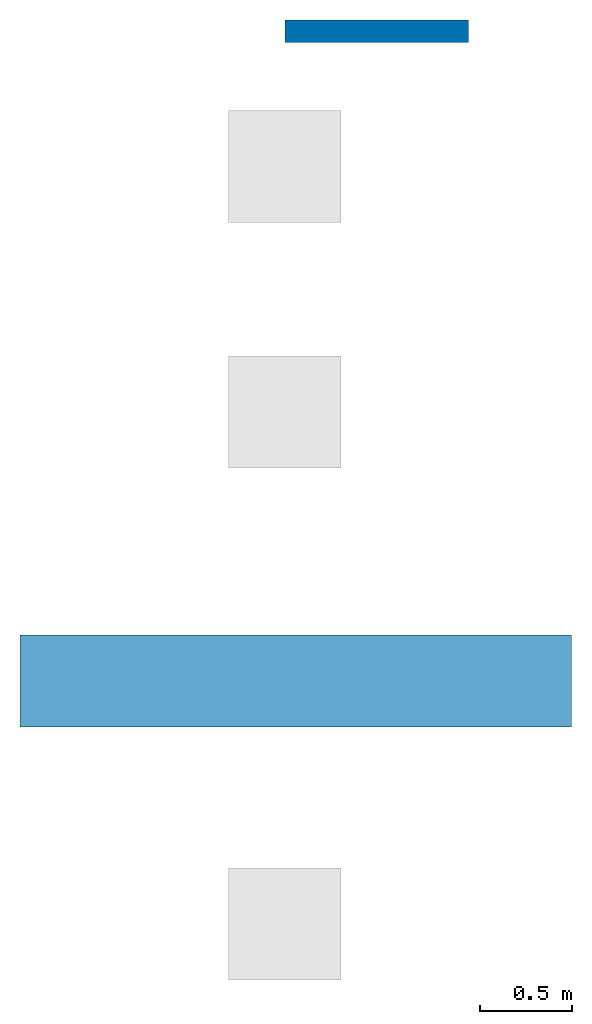
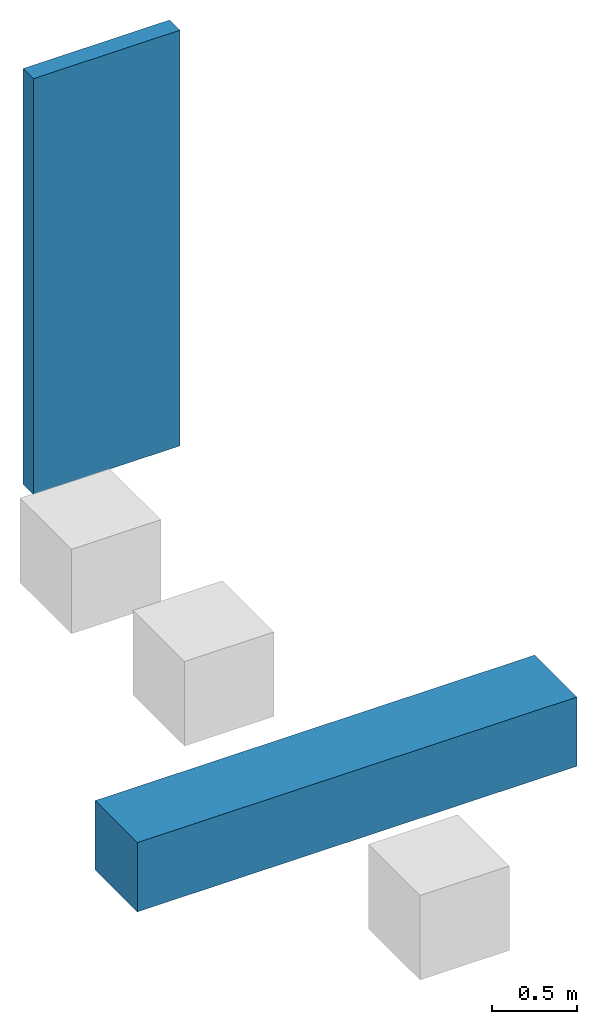
# One storey, part 1 of 2: 1 beam, 1 wall.
"""IFC4 building model written with IfcOpenShell, lengths in feet."""

from ifc_helpers import new_model, entity, si_unit, converted_unit, frame, origin_with_axes, origin_2d_with_axis, place, context, subcontext, project, spatial, indexed_curve, rectangle, outline, extrude, material, layer, layer_set, layer_usage, material_profile, profile_set, profile_usage, type_object, element, save


model = new_model("IFC4")

# Units and contexts
model_context = context("Model", 3, precision=1e-05, world=origin_with_axes())
plan_context = context("Plan", 2, precision=1e-05, world=origin_2d_with_axis())
body_context = subcontext(model_context, "Body", "Model", "MODEL_VIEW")
ifc_project = project(units=[converted_unit("AREAUNIT", "square foot", entity("IfcReal", 0.09290304), si_unit("AREAUNIT", "SQUARE_METRE"), dimensions=[2, 0, 0, 0, 0, 0, 0]), converted_unit("LENGTHUNIT", "foot", entity("IfcReal", 0.3048), si_unit("LENGTHUNIT", "METRE"), dimensions=[1, 0, 0, 0, 0, 0, 0]), converted_unit("VOLUMEUNIT", "cubic foot", entity("IfcReal", 0.0283168467116885), si_unit("VOLUMEUNIT", "CUBIC_METRE"), dimensions=[3, 0, 0, 0, 0, 0, 0]), converted_unit("PLANEANGLEUNIT", "degree", entity("IfcReal", 0.0174532925199433), si_unit("PLANEANGLEUNIT", "RADIAN"), dimensions=[0, 0, 0, 0, 0, 0, 0])], contexts=[model_context, plan_context])

# Site, building, storey
site_placement = place(None, origin_with_axes())
site = spatial("IfcSite", under=ifc_project, at=site_placement)
building_placement = place(site_placement, origin_with_axes())
building = spatial("IfcBuilding", under=site, at=building_placement, Name="Building")
storey_placement = place(building_placement, origin_with_axes())
storey = spatial("IfcBuildingStorey", under=building, at=storey_placement, Name="Storey")

# Beam
ifc_material_1 = material(Name="1_Material")
ifc_material_profile = material_profile(ifc_material_1, rectangle(XDim=1.64041994750656, YDim=1.64041994750656))
ifc_profile_set = profile_set([ifc_material_profile])
ifc_profile_usage = profile_usage(ifc_profile_set, cardinal=5)
beam_type = type_object("IfcBeamType", PredefinedType="BEAM", material=ifc_profile_set)
beam_placement = place(storey_placement, frame((-4.72472565067722, -11.3989627893203, 0.0), z_axis=(0.999999999999994, -7.54979012640429e-08, 7.54979012640429e-08), x_axis=(7.54979012640431e-08, 0.999999999999997, 7.16093850883224e-15)))
element("IfcBeam", 1, at=beam_placement, inside=storey, type_object=beam_type, material=ifc_profile_usage, Name="Beam", context=body_context, shape_type="SweptSolid", body=[
    extrude(rectangle(XDim=1.64041994750656, YDim=1.64041994750656), origin_with_axes(), (0.0, 0.0, 1.0), 9.84251968503943),
])

# Wall
ifc_layer_1 = layer(ifc_material_1, 0.200000002980232)
ifc_material_2 = material(Name="2_Material")
ifc_layer_2 = layer(ifc_material_2, 0.200000002980232)
ifc_layer_set = layer_set([ifc_layer_1, ifc_layer_2])
ifc_layer_usage = layer_usage(ifc_layer_set, "AXIS2", "POSITIVE", 0.0)
wall_type = type_object("IfcWallType", PredefinedType="SOLIDWALL", material=ifc_layer_set)
wall_placement = place(storey_placement, origin_with_axes())
element("IfcWall", 2, at=wall_placement, inside=storey, type_object=wall_type, material=ifc_layer_usage, Name="Wall", context=body_context, shape_type="SweptSolid", body=[
    extrude(outline(indexed_curve([(0.0, 0.0), (0.0, 0.400000005960464), (3.28083989501312, 0.400000005960464), (3.28083989501312, 0.0), (0.0, 0.0)], self_intersect=False)), origin_with_axes(), (0.0, 0.0, 1.0), 9.84251968503937),
])

save(model, "model.ifc")
